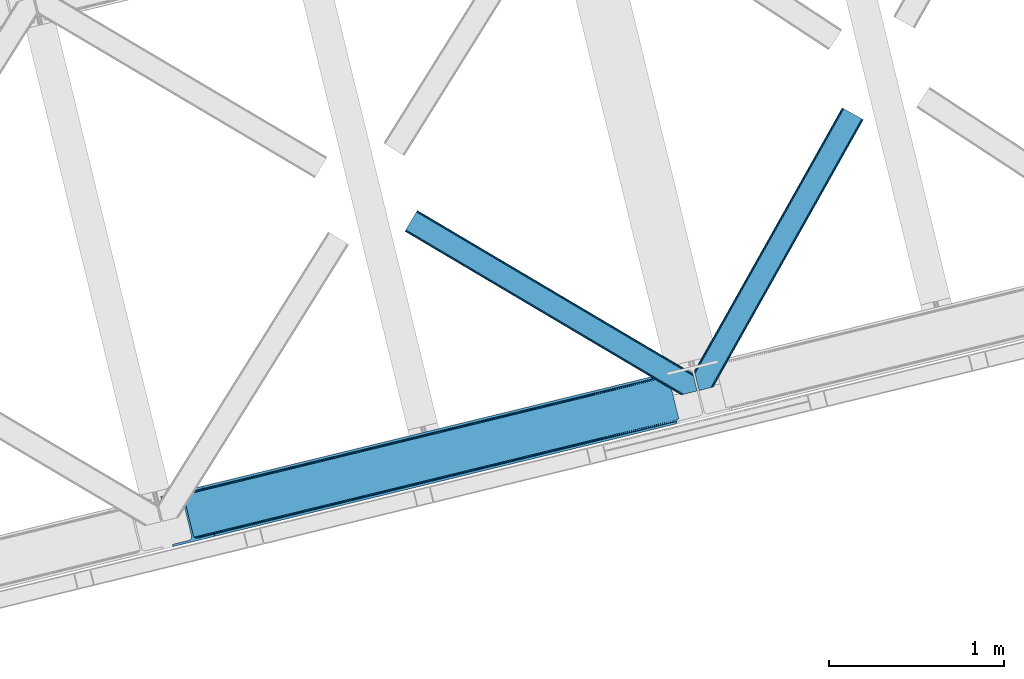
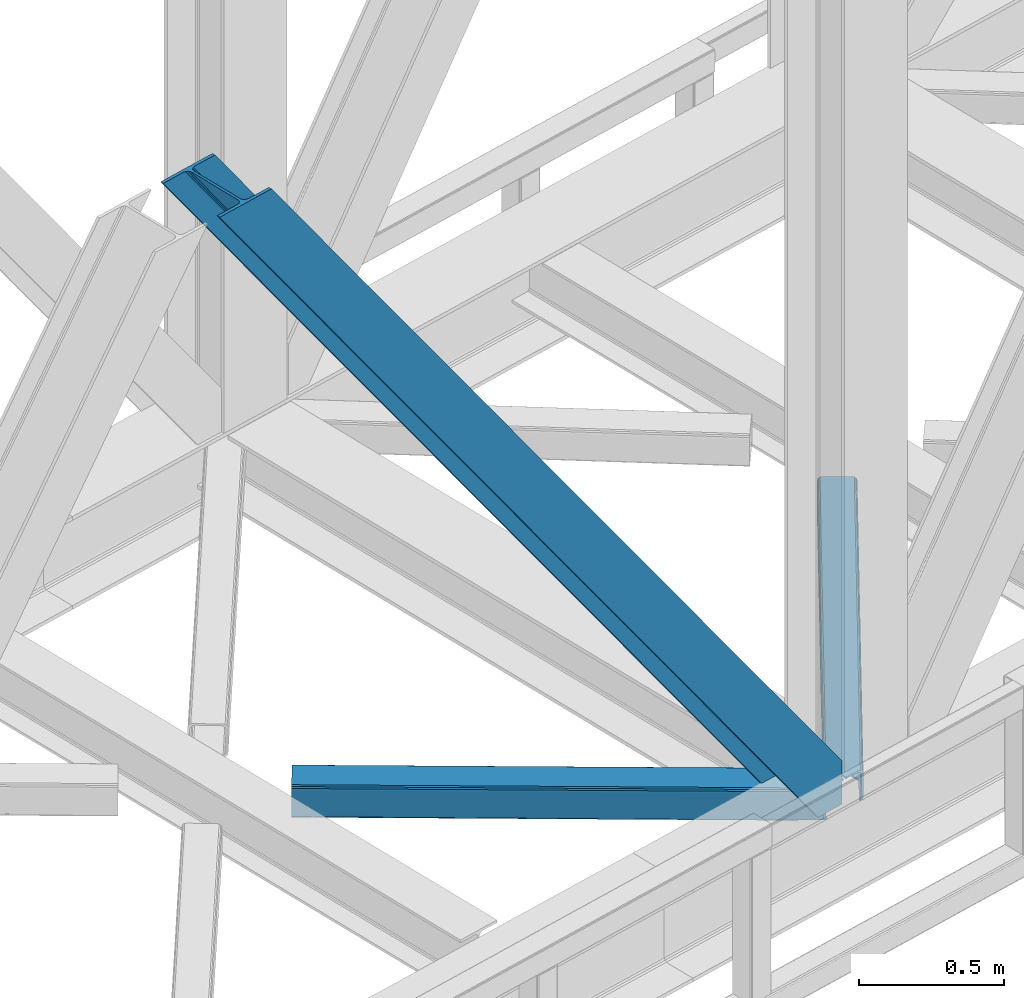
# One storey, part 69 of 93: 3 members.
"""IFC4 building model written with IfcOpenShell, lengths in millimetres."""

import ifcopenshell
import ifcopenshell.guid

model = None  # the IFC model being written
_history = None  # IfcOwnerHistory: only IFC2X3 demands one
_inside = {}  # id of a spatial element -> (the spatial element, [elements in it])
_under = {}  # id of a project, library or spatial element -> (it, [spatial elements below it])
_declared = {}  # id of a project -> (the project, [libraries it declares])
_typed = {}  # id of a type object -> (the type object, [elements of that type])
_made_of = {}  # id of a material, layer set ... -> (it, [elements and type objects made of it])


def new_model(schema):
    """Start an empty IFC model of exactly this schema.

    Asked for "IFC4X3", IfcOpenShell would pick the latest addendum, in which some entities
    have other attributes; the version numbers below select the first issue.
    IFC2X3 requires an IfcOwnerHistory on every rooted entity: one is made here for all.
    """
    global model, _history
    if schema == "IFC4X3":
        model = ifcopenshell.file(schema_version=(4, 3, 0, 0))
    else:
        model = ifcopenshell.file(schema=schema)
    _inside.clear()
    _under.clear()
    _declared.clear()
    _typed.clear()
    _made_of.clear()
    _history = None
    if model.schema == "IFC2X3":
        org = make("IfcOrganization", Name="unknown")
        user = make(
            "IfcPersonAndOrganization",
            ThePerson=make("IfcPerson", FamilyName="unknown"),
            TheOrganization=org,
        )
        app = make(
            "IfcApplication",
            ApplicationDeveloper=org,
            Version="unknown",
            ApplicationFullName="unknown",
            ApplicationIdentifier="unknown",
        )
        _history = make(
            "IfcOwnerHistory",
            OwningUser=user,
            OwningApplication=app,
            ChangeAction="ADDED",
            CreationDate=0,
        )
    return model


def make(cls, **values):
    """One entity of the class cls with the attributes given. An attribute that is None is left unset."""
    return model.create_entity(
        cls, **{name: value for name, value in values.items() if value is not None}
    )


def entity(cls, *values):
    """Any entity or typed value of the class cls, its attributes in the order of the schema. None: left unset."""
    e = model.create_entity(cls)
    for i, value in enumerate(values):
        if value is not None:
            e[i] = value
    return e


def rooted(cls, **values):
    """An entity with a GlobalId (a new one), such as an element, a storey or a relation."""
    return make(cls, GlobalId=ifcopenshell.guid.new(), OwnerHistory=_history, **values)


def si_unit(unit_type, name, prefix=None):
    """IfcSIUnit, for example si_unit("LENGTHUNIT", "METRE", prefix="MILLI")."""
    return make("IfcSIUnit", UnitType=unit_type, Prefix=prefix, Name=name)


def converted_unit(unit_type, name, factor, base, dimensions=None, offset=None):
    """IfcConversionBasedUnit, such as the inch: factor (a typed value) times the base unit."""
    return make(
        "IfcConversionBasedUnit"
        if offset is None
        else "IfcConversionBasedUnitWithOffset",
        ConversionOffset=offset,
        Dimensions=None
        if dimensions is None
        else entity("IfcDimensionalExponents", *dimensions),
        UnitType=unit_type,
        Name=name,
        ConversionFactor=make(
            "IfcMeasureWithUnit", ValueComponent=factor, UnitComponent=base
        ),
    )


def derived_unit(unit_type, elements):
    """IfcDerivedUnit: a product of units, each with its exponent."""
    return make(
        "IfcDerivedUnit",
        Elements=[
            make("IfcDerivedUnitElement", Unit=unit, Exponent=power)
            for unit, power in elements
        ],
        UnitType=unit_type,
    )


def assignment(units):
    """IfcUnitAssignment: the units of a project."""
    return None if units is None else make("IfcUnitAssignment", Units=units)


def point(xyz):
    """IfcCartesianPoint."""
    return None if xyz is None else make("IfcCartesianPoint", Coordinates=xyz)


def direction(xyz):
    """IfcDirection."""
    return None if xyz is None else make("IfcDirection", DirectionRatios=xyz)


def frame(location, z_axis=None, x_axis=None):
    """IfcAxis2Placement3D, a coordinate frame: its origin and axes. An axis left out is left unset."""
    return make(
        "IfcAxis2Placement3D",
        Location=point(location),
        Axis=direction(z_axis),
        RefDirection=direction(x_axis),
    )


def origin():
    """The frame at (0, 0, 0) with its axes left unset."""
    return frame((0.0, 0.0, 0.0))


def place(relative_to, where):
    """IfcLocalPlacement: puts the frame where relative to a parent placement (None: the world)."""
    return make(
        "IfcLocalPlacement", PlacementRelTo=relative_to, RelativePlacement=where
    )


def context(
    kind, dimensions, precision=None, world=None, true_north=None, identifier=None
):
    """IfcGeometricRepresentationContext, for example the 3D "Model" context."""
    return make(
        "IfcGeometricRepresentationContext",
        ContextIdentifier=identifier,
        ContextType=kind,
        CoordinateSpaceDimension=dimensions,
        Precision=precision,
        WorldCoordinateSystem=world,
        TrueNorth=true_north,
    )


def subcontext(parent, identifier, kind, view, scale=None):
    """IfcGeometricRepresentationSubContext, for example "Body" below "Model"."""
    return make(
        "IfcGeometricRepresentationSubContext",
        ContextIdentifier=identifier,
        ContextType=kind,
        ParentContext=parent,
        TargetScale=scale,
        TargetView=view,
    )


def project(units=None, contexts=None):
    """IfcProject with its units and contexts."""
    return rooted(
        "IfcProject",
        Name="project",
        RepresentationContexts=contexts,
        UnitsInContext=assignment(units),
    )


def spatial(cls, under=None, at=None, **own):
    """A site, building, storey or space (cls), placed at a placement, below another one or the project."""
    s = rooted(cls, ObjectPlacement=at, **own)
    if under is not None:
        _under.setdefault(under.id(), (under, []))[1].append(s)
    return s


def point_list(points):
    """IfcCartesianPointList2D or 3D."""
    cls = (
        "IfcCartesianPointList2D" if len(points[0]) == 2 else "IfcCartesianPointList3D"
    )
    return make(cls, CoordList=points)


def triangles(points, corners, closed=None, point_numbers=None):
    """IfcTriangulatedFaceSet: each triangle names its three corners, points numbered from 1."""
    return make(
        "IfcTriangulatedFaceSet",
        Coordinates=point_list(points),
        Closed=closed,
        CoordIndex=corners,
        PnIndex=point_numbers,
    )


def shape(context_of_items, identifier, shape_type, items):
    """IfcShapeRepresentation: the items that make up one representation, for example the "Body"."""
    return make(
        "IfcShapeRepresentation",
        ContextOfItems=context_of_items,
        RepresentationIdentifier=identifier,
        RepresentationType=shape_type,
        Items=items,
    )


def made_of(thing, what):
    """Note that an element or type object is made of a material, layer set ...; save() writes the relation."""
    if what is not None:
        _made_of.setdefault(what.id(), (what, []))[1].append(thing)
    return thing


def type_object(cls, material=None, **own):
    """A type object (cls), such as IfcWallType, which elements share."""
    return made_of(rooted(cls, **own), material)


def element(
    cls,
    number,
    at=None,
    inside=None,
    cuts=None,
    type_object=None,
    material=None,
    context=None,
    identifier="Body",
    shape_type=None,
    held_by="IfcProductDefinitionShape",
    body=None,
    shapes=None,
    **own,
):
    """One element of the class cls, such as IfcWall. Its Tag is "e" and its number.

    at: its placement. inside: the storey or other place that contains it. cuts: it is an
    opening in that element (IfcRelVoidsElement). A single representation is given by context,
    identifier, shape_type and body (its items); several are given by shapes. held_by: the class
    of the entity that holds the representations. save() writes the other relations.
    """
    e = rooted(cls, Tag="e%d" % number, ObjectPlacement=at, **own)
    if body is not None:
        shapes = [shape(context, identifier, shape_type, body)]
    if shapes is not None:
        e.Representation = make(held_by, Representations=shapes)
    if inside is not None:
        _inside.setdefault(inside.id(), (inside, []))[1].append(e)
    if cuts is not None:
        rooted(
            "IfcRelVoidsElement", RelatingBuildingElement=cuts, RelatedOpeningElement=e
        )
    if type_object is not None:
        _typed.setdefault(type_object.id(), (type_object, []))[1].append(e)
    return made_of(e, material)


def aggregate(whole, parts):
    """IfcRelAggregates: a whole, such as a stair, and the parts it consists of."""
    return rooted("IfcRelAggregates", RelatingObject=whole, RelatedObjects=parts)


def save(model, path):
    """Write the relations noted so far, then the file.

    IfcRelAggregates (storeys below a building ...), IfcRelContainedInSpatialStructure (elements
    in a storey), IfcRelDefinesByType, IfcRelAssociatesMaterial and IfcRelDeclares: one each for
    every whole, place, type object, material and project.
    """
    for whole, parts in _under.values():
        aggregate(whole, parts)
    for where, things in _inside.values():
        rooted(
            "IfcRelContainedInSpatialStructure",
            RelatedElements=things,
            RelatingStructure=where,
        )
    for kind, things in _typed.values():
        rooted("IfcRelDefinesByType", RelatedObjects=things, RelatingType=kind)
    for what, things in _made_of.values():
        rooted("IfcRelAssociatesMaterial", RelatedObjects=things, RelatingMaterial=what)
    for by, libraries in _declared.values():
        rooted("IfcRelDeclares", RelatingContext=by, RelatedDefinitions=libraries)
    model.write(path)


model = new_model("IFC4")

# Units and contexts
model_context = context("Model", 3, precision=0.01, world=origin(), true_north=direction((6.12303176911189e-17, 1.0)))
plan_context = context("Plan", 3, precision=0.01, world=origin(), true_north=direction((6.12303176911189e-17, 1.0)))
body_context = subcontext(model_context, "Body", "Model", "MODEL_VIEW")
ifc_project = project(units=[si_unit("LENGTHUNIT", "METRE", prefix="MILLI"), si_unit("AREAUNIT", "SQUARE_METRE"), si_unit("VOLUMEUNIT", "CUBIC_METRE"), converted_unit("PLANEANGLEUNIT", "DEGREE", entity("IfcRatioMeasure", 0.0174532925199433), si_unit("PLANEANGLEUNIT", "RADIAN"), dimensions=[0, 0, 0, 0, 0, 0, 0]), si_unit("MASSUNIT", "GRAM", prefix="KILO"), derived_unit("MASSDENSITYUNIT", [(si_unit("MASSUNIT", "GRAM", prefix="KILO"), 1), (si_unit("LENGTHUNIT", "METRE"), -3)]), derived_unit("MOMENTOFINERTIAUNIT", [(si_unit("LENGTHUNIT", "METRE"), 4)]), si_unit("TIMEUNIT", "SECOND"), si_unit("FREQUENCYUNIT", "HERTZ"), si_unit("THERMODYNAMICTEMPERATUREUNIT", "DEGREE_CELSIUS"), derived_unit("THERMALTRANSMITTANCEUNIT", [(si_unit("MASSUNIT", "GRAM", prefix="KILO"), 1), (si_unit("THERMODYNAMICTEMPERATUREUNIT", "KELVIN"), -1), (si_unit("TIMEUNIT", "SECOND"), -3)]), derived_unit("VOLUMETRICFLOWRATEUNIT", [(si_unit("LENGTHUNIT", "METRE"), 3), (si_unit("TIMEUNIT", "SECOND"), -1)]), derived_unit("MASSFLOWRATEUNIT", [(si_unit("MASSUNIT", "GRAM", prefix="KILO"), 1), (si_unit("TIMEUNIT", "SECOND"), -1)]), derived_unit("ROTATIONALFREQUENCYUNIT", [(si_unit("TIMEUNIT", "SECOND"), -1)]), si_unit("ELECTRICCURRENTUNIT", "AMPERE"), si_unit("ELECTRICVOLTAGEUNIT", "VOLT"), si_unit("POWERUNIT", "WATT"), si_unit("FORCEUNIT", "NEWTON", prefix="KILO"), si_unit("ILLUMINANCEUNIT", "LUX"), si_unit("LUMINOUSFLUXUNIT", "LUMEN"), si_unit("LUMINOUSINTENSITYUNIT", "CANDELA"), derived_unit("USERDEFINED", [(si_unit("MASSUNIT", "GRAM", prefix="KILO"), -1), (si_unit("LENGTHUNIT", "METRE"), -2), (si_unit("TIMEUNIT", "SECOND"), 3), (si_unit("LUMINOUSFLUXUNIT", "LUMEN"), 1)]), derived_unit("LINEARVELOCITYUNIT", [(si_unit("LENGTHUNIT", "METRE"), 1), (si_unit("TIMEUNIT", "SECOND"), -1)]), si_unit("PRESSUREUNIT", "PASCAL"), derived_unit("USERDEFINED", [(si_unit("LENGTHUNIT", "METRE"), -2), (si_unit("MASSUNIT", "GRAM", prefix="KILO"), 1), (si_unit("TIMEUNIT", "SECOND"), -2)]), derived_unit("LINEARFORCEUNIT", [(si_unit("MASSUNIT", "GRAM", prefix="KILO"), 1), (si_unit("LENGTHUNIT", "METRE"), 1), (si_unit("TIMEUNIT", "SECOND"), -2), (si_unit("LENGTHUNIT", "METRE"), -1)]), derived_unit("PLANARFORCEUNIT", [(si_unit("MASSUNIT", "GRAM", prefix="KILO"), 1), (si_unit("LENGTHUNIT", "METRE"), 1), (si_unit("TIMEUNIT", "SECOND"), -2), (si_unit("LENGTHUNIT", "METRE"), -2)])], contexts=[model_context, plan_context])

# Site, building, storey
site_placement = place(None, origin())
site = spatial("IfcSite", under=ifc_project, at=site_placement, CompositionType="ELEMENT")
building_placement = place(site_placement, origin())
building = spatial("IfcBuilding", under=site, at=building_placement, CompositionType="ELEMENT")
storey_placement = place(building_placement, frame((0.0, 0.0, 15900.0)))
storey = spatial("IfcBuildingStorey", under=building, at=storey_placement, CompositionType="ELEMENT", Elevation=15900.0)

# Members
member_type_1 = type_object("IfcMemberType", PredefinedType="BRACE")
member_1_placement = place(storey_placement, frame((-14085.9518371582, 14033.1887786865, 3694.99929199219)))
element("IfcMember", 1, at=member_1_placement, inside=storey, type_object=member_type_1, ObjectType="Steel Vertical Brace", PredefinedType="BRACE", context=body_context, shape_type="Tessellation", body=[
    triangles([(2966.89216003418, 730.998403930664, 0.80925292968459), (2967.55374755859, 730.015905761718, 1.10690917968532), (2966.08058166504, 729.656625366211, 0.0), (2964.18651123047, 737.429406738282, 0.0), (2962.43894348145, 728.768307495116, 8.31577148437282), (2962.43894348145, 728.768307495116, 0.0), (2505.8586730957, 612.605630493164, 658.855133056641), (2511.3606628418, 609.931375122071, 662.301434326171), (2954.04410705566, 717.839904785156, 38.6743835449197), (2954.16968078613, 719.764205932617, 32.1678039550752), (2501.41243286133, 617.533236694335, 656.552947998047), (2958.54266967773, 726.956790161132, 14.8293273925774), (2955.07776489258, 722.243124389648, 26.1867736816384), (2955.64168395996, 723.795355224609, 22.4381652832017), (655.166986083985, 156.054428100586, 3289.34108276367), (649.438265991212, 156.067218017577, 3285.27854003906), (213.882293701172, 48.4865753173817, 3911.00081176758), (205.271191406249, 47.7970825195298, 3911.00081176758), (643.936276245116, 158.742636108398, 3281.83223876953), (197.320513916016, 49.8760253906239, 3911.00081176758), (639.490036010742, 163.669079589843, 3279.53005371094), (191.242977905273, 54.4048187255848, 3911.00081176758), (636.783224487304, 170.100082397461, 3278.7231262207), (187.962945556641, 60.695132446288, 3911.00081176758), (2954.16154174805, 716.45859375, 50.6410949707024), (2517.08822021484, 609.91742248535, 666.36397705078), (2051.60849304199, 496.451092529296, 1322.10767211914), (2045.87977294922, 496.465045166015, 1318.04512939453), (1580.39888305664, 382.999877929688, 1973.78882446289), (1586.12760314941, 382.985925292967, 1977.85369262695), (1114.91799316406, 269.533547973631, 2629.53251953125), (1120.64671325684, 269.519595336913, 2633.59738769531), (2040.37778320312, 499.140463256836, 1314.598828125), (1574.89805603027, 385.674133300781, 1970.34484863281), (1109.41716613769, 272.208966064452, 2626.08854370117), (2035.93154296875, 504.066906738281, 1312.29896850586), (1570.45065307617, 390.601739501952, 1968.04266357422), (1104.97092590332, 277.135409545897, 2623.78635864258), (2498.70562133789, 623.963076782225, 655.74602050781), (2033.22473144531, 510.496746826171, 1311.48971557617), (1567.74384155273, 397.031579589842, 1967.23341064453), (1102.26411437988, 283.565249633788, 2622.97710571289), (2909.00499572754, 963.80047302246, 0.0), (2443.52526855469, 850.335305786133, 655.74602050781), (1978.04437866211, 736.868975830077, 1311.48971557617), (1512.56348876953, 623.402645874023, 1967.23341064453), (1047.08259887695, 509.937478637694, 2622.97710571289), (581.602871704101, 396.47114868164, 3278.7231262207), (132.78143005371, 287.066198730468, 3911.00081176758), (307.434722900391, 71.2909973144524, 3911.00081176758), (2954.16154174805, 716.45859375, 182.433050537107), (2954.3522277832, 715.476095581054, 0.0), (2954.16968078613, 719.764205932617, 0.0), (2954.3522277832, 715.476095581054, 182.495837402341), (2955.64168395996, 723.795355224609, 0.0), (2958.54266967773, 726.956790161132, 0.0), (2957.19507751465, 703.817504882813, 182.495837402341), (310.513604736328, 58.6603729248036, 3911.00081176758), (2957.19507751465, 703.817504882813, 0.0), (2846.09255676269, 676.734274291992, 0.0), (69.8643402099606, 0.0, 3911.00081176758), (2843.01367492676, 689.364898681641, 0.0), (66.7854583740227, 12.6294616699215, 3911.00081176758), (160.337887573241, 35.4338836669922, 3911.00081176758), (2936.56610412598, 712.169320678711, 0.0), (2953.96039123535, 734.936535644531, 0.0), (2953.94295043945, 727.841619873047, 0.0), (177.732174682616, 58.2010986328114, 3911.00081176758), (177.714733886718, 51.1073455810547, 3911.00081176758), (2950.63036193848, 721.02459411621, 0.0), (174.402145385742, 44.2891571044911, 3911.00081176758), (2944.52840881348, 715.520278930664, 0.0), (168.300192260742, 38.7848419189449, 3911.00081176758), (2898.78003845215, 961.307601928711, 0.0), (122.551821899415, 284.573327636717, 3911.00081176758), (2872.85952758789, 973.516159057617, 0.0), (2881.47062988281, 974.205651855469, 0.0), (105.243576049805, 297.47021484375, 3911.00081176758), (96.6313110351566, 296.781884765624, 3911.00081176758), (2889.42130737305, 972.1278717041, 0.0), (113.193090820312, 295.392434692381, 3911.00081176758), (2895.49884338379, 967.597915649414, 0.0), (119.271789550781, 290.86364135742, 3911.00081176758), (3.07888183593786, 273.977462768555, 3911.00081176758), (2779.30709838867, 950.711737060547, 0.0), (2776.22821655273, 963.342361450195, 0.0), (0.0, 286.606924438476, 3911.00081176758), (142.214575195312, 306.482455444335, 3911.00081176758), (150.176879882813, 309.833413696288, 3911.00081176758), (136.111459350586, 300.979302978514, 3911.00081176758), (132.800033569336, 294.161114501952, 3911.00081176758), (240.650427246093, 345.268460083007, 3911.00081176758), (243.729309082031, 332.637835693358, 3911.00081176758), (2887.33073730469, 990.424429321289, 182.495837402341), (2887.33073730469, 990.424429321289, 0.0), (2890.45496520996, 977.805432128906, 182.433050537107), (2890.17242431641, 978.765838623047, 182.495837402341), (1522.42102661133, 644.332763671875, 1977.85369262695), (591.460409545898, 417.401266479492, 3289.34108276367), (1056.94129943848, 530.867596435546, 2633.59738769531), (1987.90191650391, 757.799093627929, 1322.10767211914), (2453.38280639648, 871.264260864258, 666.36397705078), (2890.45496520996, 977.805432128906, 50.6410949707024), (2890.17242431641, 978.765838623047, 0.0), (2890.98749084473, 976.525277709961, 38.6743835449197), (2892.14904785156, 974.998626708984, 33.1630920410134), (2891.98277893066, 974.874215698243, 0.0), (2893.56989135742, 973.138275146484, 26.4425720214822), (2895.14653930664, 971.973229980469, 22.4381652832017), (2903.46928710938, 970.684936523438, 8.31577148437282), (2903.46928710938, 970.684936523438, 0.0), (2899.17652587891, 970.50122680664, 0.0), (2899.17652587891, 970.50122680664, 14.8293273925774), (2895.14653930664, 971.973229980469, 0.0), (2907.11092529297, 971.573254394531, 0.0), (2444.64961853027, 863.71007080078, 658.855133056641), (2442.96948852539, 857.289532470702, 656.552947998047), (2908.44921569824, 970.754699707031, 0.80925292968459), (2908.58409118652, 971.932534790039, 1.10690917968532), (581.047091674805, 403.426538085936, 3279.53005371094), (582.727221679688, 409.845913696288, 3281.83223876953), (586.380487060547, 414.752590942382, 3285.27854003906), (2448.30288391113, 868.615585327148, 662.301434326171), (1977.48859863281, 743.823202514648, 1312.29896850586), (1512.00770874024, 630.358035278319, 1968.04266357422), (1046.52681884766, 516.891705322265, 2623.78635864258), (1979.16872863769, 750.243740844726, 1314.598828125), (1513.68900146484, 636.777410888672, 1970.34484863281), (1048.20811157226, 523.312243652343, 2626.08854370117), (1982.82199401856, 755.15041809082, 1318.04512939453), (1517.34110412598, 641.684088134765, 1973.78882446289), (1051.86137695313, 528.218920898436, 2629.53251953125)], [[1, 2, 3], [3, 4, 1], [2, 5, 6], [6, 3, 2], [7, 8, 9], [9, 10, 7], [11, 12, 5], [5, 1, 11], [11, 7, 13], [13, 14, 11], [14, 12, 11], [15, 16, 17], [18, 17, 16], [16, 19, 18], [20, 18, 19], [19, 21, 20], [22, 20, 21], [21, 23, 22], [24, 22, 23], [5, 2, 1], [10, 13, 7], [25, 9, 8], [8, 26, 25], [26, 8, 27], [28, 27, 8], [27, 28, 29], [29, 30, 27], [30, 29, 31], [31, 32, 30], [32, 31, 16], [16, 15, 32], [8, 7, 33], [33, 28, 8], [28, 33, 34], [34, 29, 28], [29, 34, 31], [35, 31, 34], [31, 35, 16], [19, 16, 35], [7, 11, 33], [36, 33, 11], [33, 36, 34], [37, 34, 36], [34, 37, 35], [38, 35, 37], [35, 38, 21], [21, 19, 35], [1, 4, 11], [39, 11, 4], [11, 39, 36], [40, 36, 39], [36, 40, 37], [41, 37, 40], [37, 41, 38], [42, 38, 41], [38, 42, 21], [23, 21, 42], [4, 43, 44], [45, 39, 44], [41, 40, 45], [41, 45, 46], [44, 39, 4], [45, 40, 39], [42, 41, 46], [46, 47, 42], [47, 48, 23], [49, 24, 48], [47, 23, 42], [48, 24, 23], [50, 51, 30], [30, 32, 50], [32, 15, 50], [17, 50, 15], [27, 30, 51], [51, 25, 26], [26, 27, 51], [52, 9, 25], [52, 53, 10], [10, 9, 52], [25, 51, 54], [54, 52, 25], [14, 53, 55], [53, 14, 13], [10, 53, 13], [56, 12, 55], [14, 55, 12], [6, 5, 56], [12, 56, 5], [57, 54, 58], [54, 51, 50], [50, 58, 54], [57, 59, 52], [52, 54, 57], [58, 60, 57], [58, 61, 60], [60, 59, 57], [62, 60, 63], [61, 63, 60], [63, 64, 62], [65, 62, 64], [66, 67, 68], [69, 68, 67], [67, 70, 69], [71, 69, 70], [70, 72, 71], [73, 71, 72], [72, 65, 73], [64, 73, 65], [74, 66, 75], [68, 75, 66], [76, 77, 78], [78, 79, 76], [77, 80, 81], [81, 78, 77], [80, 82, 83], [83, 81, 80], [82, 74, 75], [75, 83, 82], [79, 84, 85], [85, 76, 79], [86, 85, 87], [84, 87, 85], [75, 68, 49], [71, 73, 18], [64, 61, 17], [63, 61, 64], [73, 64, 17], [68, 69, 22], [69, 71, 20], [81, 88, 78], [87, 79, 89], [79, 78, 89], [87, 84, 79], [81, 83, 90], [83, 75, 91], [49, 68, 24], [17, 18, 73], [22, 69, 20], [18, 20, 71], [22, 24, 68], [58, 17, 61], [58, 50, 17], [89, 78, 88], [90, 83, 91], [49, 91, 75], [90, 88, 81], [89, 92, 87], [92, 89, 93], [92, 86, 87], [86, 92, 94], [95, 86, 94], [96, 97, 93], [97, 94, 92], [92, 93, 97], [98, 96, 93], [93, 99, 100], [99, 93, 89], [100, 98, 93], [96, 98, 101], [101, 102, 96], [103, 96, 102], [97, 104, 94], [95, 94, 104], [104, 105, 106], [96, 103, 97], [104, 97, 103], [103, 105, 104], [107, 108, 109], [107, 106, 108], [110, 111, 112], [112, 113, 110], [113, 112, 114], [114, 109, 113], [109, 114, 107], [106, 107, 104], [53, 70, 55], [76, 86, 95], [85, 86, 76], [77, 76, 95], [104, 80, 77], [77, 95, 104], [104, 107, 80], [60, 65, 59], [52, 72, 70], [65, 72, 59], [60, 62, 65], [70, 53, 52], [52, 59, 72], [43, 66, 74], [82, 112, 74], [80, 114, 82], [80, 107, 114], [82, 114, 112], [111, 43, 74], [112, 111, 74], [43, 111, 115], [4, 66, 43], [56, 66, 6], [55, 70, 67], [67, 66, 56], [56, 55, 67], [4, 6, 66], [3, 6, 4], [116, 113, 109], [117, 118, 113], [113, 116, 117], [109, 108, 116], [118, 119, 110], [110, 113, 118], [48, 120, 91], [91, 49, 48], [120, 121, 90], [90, 91, 120], [121, 122, 88], [88, 90, 121], [122, 99, 89], [89, 88, 122], [105, 103, 123], [102, 123, 103], [106, 116, 108], [116, 106, 105], [123, 116, 105], [43, 118, 44], [117, 44, 118], [44, 117, 124], [124, 45, 44], [45, 124, 125], [125, 46, 45], [46, 125, 126], [126, 47, 46], [47, 126, 120], [120, 48, 47], [117, 116, 127], [127, 124, 117], [124, 127, 128], [128, 125, 124], [125, 128, 129], [129, 126, 125], [126, 129, 121], [121, 120, 126], [116, 123, 127], [130, 127, 123], [127, 130, 128], [131, 128, 130], [128, 131, 132], [132, 129, 128], [129, 132, 122], [122, 121, 129], [123, 102, 101], [101, 130, 123], [130, 101, 131], [98, 131, 101], [131, 98, 132], [100, 132, 98], [132, 100, 122], [99, 122, 100], [110, 119, 111], [115, 111, 119], [119, 118, 115], [43, 115, 118]]),
])
member_type_2 = type_object("IfcMemberType", PredefinedType="BRACE")
member_2_placement = place(storey_placement, frame((-11031.4278167725, 14926.1819458008, 3510.00011901855)))
element("IfcMember", 2, at=member_2_placement, inside=storey, type_object=member_type_2, ObjectType="Steel Horizontal Brace", PredefinedType="BRACE", context=body_context, shape_type="Tessellation", body=[
    triangles([(967.681631469726, 1549.66471252442, 122.500662231447), (966.517749023436, 1550.31583557129, 129.197927856447), (108.48872680664, 19.7604217529297, 122.500662231447), (106.717904663084, 19.3290527343761, 129.197927856447), (963.210974121093, 1552.17386169434, 134.874325561526), (101.675189208983, 18.1000579833999, 134.874325561526), (958.258950805663, 1554.95276184082, 138.667117309571), (94.1337890625, 16.2617980957039, 138.667117309571), (952.418609619141, 1558.23279418945, 139.999594116212), (85.2320068359368, 14.0921630859375, 139.999594116212), (967.681631469726, 1549.66471252442, 17.5000946044929), (108.48872680664, 19.7604217529297, 17.5000946044929), (6.07521057128906, 87.5702362060547, 139.999594116212), (27.4215820312493, 0.0, 139.999594116212), (860.870709228515, 1609.64826049805, 139.999594116212), (855.030368041991, 1612.92713012695, 138.667117309571), (3.75093383788953, 97.1068634033218, 138.667117309571), (850.082995605468, 1615.70719299317, 134.874325561526), (1.7801239013661, 105.192416381837, 134.874325561526), (846.772732543945, 1617.56405639648, 129.197927856447), (0.46276245117042, 110.594412231447, 129.197927856447), (845.612338256835, 1618.21750488281, 122.500662231447), (0.0, 112.491970825196, 122.500662231447), (845.612338256835, 1618.21750488281, 17.5000946044929), (0.0, 112.491970825196, 17.5000946044929), (966.517749023436, 1550.31583557129, 10.8028289794929), (963.210974121093, 1552.17386169434, 5.12526855468968), (157.746185302734, 111.400177001953, 9.52034912109593), (158.140347290038, 112.965197753907, 8.76225585937573), (158.27173461914, 113.467492675782, 8.52041015625218), (157.353186035156, 117.235867309571, 5.12526855468968), (106.36094970703, 19.2418487548839, 10.8679412841811), (105.931906127929, 19.1372039794933, 9.52034912109593), (952.418609619141, 1558.23279418945, 0.0), (958.258950805663, 1554.95276184082, 1.33247680664135), (153.058099365233, 134.858047485352, 0.0), (155.382376098632, 125.321420288086, 1.33247680664135), (124.438916015624, 252.261346435547, 0.0), (94.4581878662102, 244.952490234376, 0.0), (860.870709228515, 1609.64826049805, 0.0), (153.051123046875, 130.664117431641, 9.52034912109593), (153.142977905272, 131.5815032959, 9.31571044922021), (153.232507324217, 132.509353637695, 9.10758361816625), (153.325524902342, 133.426739501954, 8.90294494629052), (152.944152832031, 135.321972656251, 8.42274169922166), (87.952770996093, 14.7549133300781, 9.52034912109593), (150.628015136717, 144.8272064209, 6.99957275390625), (124.438916015624, 252.261346435547, 6.99957275390625), (952.15816040039, 1558.38162231445, 8.3320495605476), (946.317819213866, 1561.66049194336, 6.99957275390625), (957.105532836913, 1555.60039672852, 12.1260040283232), (92.375756835936, 15.832754516603, 12.1260040283232), (961.576190185546, 1553.09124755859, 24.4996673583992), (960.415795898436, 1553.7435333252, 17.8035644531265), (99.1858062744141, 17.4931182861328, 24.4996673583992), (97.4138214111317, 17.0617492675792, 17.8035644531265), (103.762271118163, 247.220956420899, 6.99957275390625), (866.972662353515, 1606.21940002442, 6.99957275390625), (85.5610565185543, 242.784017944337, 1.33247680664135), (91.7385864257813, 244.289739990236, 9.52034912109593), (78.0161682128892, 240.944595336914, 5.12526855468968), (95.0593139648427, 245.098992919922, 8.82504272460938), (73.7641021728505, 239.908612060548, 9.52034912109593), (846.772732543945, 1617.56405639648, 10.8028289794929), (4.59390563964735, 117.490502929688, 10.8702667236357), (850.082995605468, 1615.70719299317, 5.12526855468968), (5.69267578124891, 118.696243286133, 9.52034912109593), (855.030368041991, 1612.92713012695, 1.33247680664135), (0.0104644775383349, 112.452438354492, 16.5199218750022), (10.3889007568359, 99.4323028564468, 9.52034912109593), (7.36001586914063, 100.839193725587, 12.1260040283232), (3.09864807128906, 99.7811187744155, 16.5199218750022), (852.878173828125, 1614.13752136231, 17.8035644531265), (851.714291381835, 1614.78864440918, 24.4996673583992), (2.43008422851563, 102.522811889648, 24.4996673583992), (2.98586425781104, 100.243881225586, 17.8686767578147), (856.183786010741, 1612.27949523926, 12.1260040283232), (861.136972045897, 1609.49943237305, 8.3320495605476), (961.576190185546, 1553.09124755859, 115.501089477541), (99.1858062744141, 17.4931182861328, 115.501089477541), (97.4138214111317, 17.0617492675792, 122.196029663086), (84.8297058105454, 13.9933319091797, 131.667544555665), (75.9325744628895, 11.8248596191406, 133.000021362306), (27.4215820312493, 0.0, 133.000021362306), (92.375756835936, 15.832754516603, 127.87475280762), (946.317819213866, 1561.66049194336, 133.000021362306), (952.15816040039, 1558.38162231445, 131.667544555665), (957.105532836913, 1555.60039672852, 127.87475280762), (960.415795898436, 1553.7435333252, 122.196029663086), (856.183786010741, 1612.27949523926, 127.87475280762), (866.972662353515, 1606.21940002442, 133.000021362306), (861.136972045897, 1609.49943237305, 131.667544555665), (851.714291381835, 1614.78864440918, 115.501089477541), (852.878173828125, 1614.13752136231, 122.196029663086), (6.18101806640516, 87.1388671875011, 131.667544555665), (8.50529479980469, 77.6010772705085, 133.000021362306), (4.21020812988172, 95.2232574462905, 127.87475280762), (2.43008422851563, 102.522811889648, 115.501089477541), (2.89284667968604, 100.626416015626, 122.196029663086)], [[1, 2, 3], [4, 3, 2], [2, 5, 4], [6, 4, 5], [5, 7, 6], [8, 6, 7], [7, 9, 8], [10, 8, 9], [11, 1, 3], [3, 12, 11], [13, 10, 9], [10, 13, 14], [9, 15, 13], [15, 16, 17], [17, 13, 15], [16, 18, 19], [19, 17, 16], [18, 20, 21], [21, 19, 18], [20, 22, 23], [23, 21, 20], [22, 24, 25], [25, 23, 22], [26, 11, 12], [27, 28, 29], [30, 31, 27], [26, 32, 28], [28, 27, 26], [32, 33, 28], [34, 35, 36], [37, 36, 35], [35, 27, 37], [31, 37, 27], [12, 32, 26], [38, 39, 40], [36, 38, 34], [40, 34, 38], [41, 42, 28], [42, 43, 29], [43, 44, 29], [44, 45, 30], [33, 46, 28], [41, 28, 46], [45, 47, 36], [38, 47, 48], [47, 38, 36], [45, 31, 30], [45, 36, 37], [37, 31, 45], [49, 50, 47], [51, 49, 45], [45, 44, 51], [51, 43, 42], [43, 51, 44], [42, 41, 51], [51, 41, 52], [46, 52, 41], [47, 45, 49], [53, 54, 55], [56, 55, 54], [54, 51, 56], [52, 56, 51], [48, 47, 50], [57, 48, 58], [50, 58, 48], [59, 60, 61], [57, 38, 48], [57, 62, 39], [57, 39, 38], [39, 60, 59], [61, 60, 63], [62, 60, 39], [24, 64, 65], [65, 25, 24], [65, 64, 63], [64, 66, 61], [61, 63, 64], [63, 67, 65], [66, 68, 59], [59, 61, 66], [68, 40, 39], [39, 59, 68], [65, 69, 25], [65, 70, 71], [65, 67, 70], [71, 69, 65], [72, 69, 71], [70, 67, 60], [63, 60, 67], [73, 74, 75], [73, 72, 71], [73, 76, 72], [77, 71, 60], [60, 78, 77], [60, 62, 78], [71, 70, 60], [78, 62, 57], [57, 58, 78], [71, 77, 73], [75, 76, 73], [79, 53, 55], [55, 80, 79], [81, 3, 4], [82, 8, 10], [14, 83, 10], [83, 14, 84], [83, 82, 10], [85, 8, 82], [85, 81, 6], [6, 8, 85], [4, 6, 81], [55, 12, 3], [52, 33, 56], [81, 80, 3], [52, 46, 33], [55, 56, 12], [80, 55, 3], [32, 12, 56], [56, 33, 32], [86, 87, 82], [82, 83, 86], [87, 88, 85], [85, 82, 87], [88, 89, 81], [81, 85, 88], [89, 79, 80], [80, 81, 89], [26, 51, 54], [53, 1, 11], [26, 54, 11], [26, 27, 51], [54, 53, 11], [51, 27, 35], [50, 34, 40], [34, 49, 35], [49, 34, 50], [49, 51, 35], [2, 88, 5], [79, 1, 53], [1, 89, 2], [89, 1, 79], [2, 89, 88], [9, 86, 15], [7, 5, 88], [88, 87, 7], [87, 86, 9], [9, 7, 87], [77, 68, 66], [40, 58, 50], [40, 78, 58], [78, 40, 68], [77, 78, 68], [74, 24, 22], [64, 73, 77], [66, 64, 77], [73, 64, 24], [74, 73, 24], [16, 90, 18], [15, 86, 91], [91, 92, 15], [92, 90, 16], [16, 15, 92], [20, 18, 90], [22, 93, 74], [94, 22, 20], [22, 94, 93], [94, 20, 90], [95, 96, 13], [96, 14, 13], [96, 84, 14], [17, 95, 13], [97, 17, 19], [97, 95, 17], [72, 76, 69], [23, 98, 99], [99, 19, 21], [19, 99, 97], [21, 23, 99], [23, 75, 98], [25, 69, 76], [25, 75, 23], [75, 25, 76], [83, 96, 86], [83, 84, 96], [91, 86, 96], [74, 93, 75], [98, 75, 93], [93, 94, 98], [99, 98, 94], [94, 90, 99], [97, 99, 90], [90, 92, 97], [95, 97, 92], [92, 91, 95], [96, 95, 91]]),
])
member_type_3 = type_object("IfcMemberType", PredefinedType="BRACE")
member_3_placement = place(storey_placement, frame((-12687.8790344238, 14901.0346435547, 3510.00011901855)))
element("IfcMember", 3, at=member_3_placement, inside=storey, type_object=member_type_3, ObjectType="Steel Horizontal Brace", PredefinedType="BRACE", context=body_context, shape_type="Tessellation", body=[
    triangles([(1468.19991760254, 208.966314697265, 0.0), (1502.96058654785, 66.3657165527329, 0.0), (8.91340942382703, 950.879168701171, 0.0), (62.4054931640621, 1041.23295593262, 0.0), (0.677865600584482, 936.96722717285, 10.8028289794929), (1582.93710021973, 0.542990112304324, 10.8679412841811), (1580.70932922363, 0.0, 17.5000946044929), (1509.31950073242, 44.5019348144524, 9.52034912109593), (2.61030578613281, 940.230981445311, 5.12526855468968), (1507.05684814453, 49.5597656249993, 5.12526855468968), (1507.93353881836, 45.9669616699211, 8.52041015625218), (1508.98463745117, 44.8554016113267, 9.27850341796875), (1508.62884521484, 45.2344482421868, 9.02037963867406), (1508.26840209961, 45.6123321533196, 8.76225585937573), (1583.38939819336, 0.653448486327761, 9.52034912109593), (1505.17789306641, 57.2709228515614, 1.33247680664135), (5.50315246581886, 945.116729736328, 1.33247680664135), (0.0, 935.820785522461, 17.5000946044929), (1580.70932922363, 0.0, 122.500662231447), (0.0, 935.820785522461, 122.500662231447), (1595.73399353027, 3.66256713867188, 138.667117309571), (1605.04156494141, 5.93103332519422, 139.999594116212), (8.91340942382703, 950.879168701171, 139.999594116212), (5.50315246581886, 945.116729736328, 138.667117309571), (1587.83912658691, 1.73826599121094, 134.874325561526), (2.61030578613281, 940.230981445311, 134.874325561526), (1582.56154174805, 0.451135253904795, 129.197927856447), (0.677865600584482, 936.96722717285, 129.197927856447), (1503.00476989746, 66.183169555663, 8.52041015625218), (1503.36521301269, 65.041378784179, 8.90294494629052), (1503.8558807373, 64.3216552734375, 9.10758361816625), (1504.35003662109, 63.5914672851559, 9.31571044922021), (1504.84186706543, 62.8729064941399, 9.52034912109593), (1602.19522705078, 5.23688964843677, 9.52034912109593), (9.06572570800745, 951.139617919922, 8.3320495605476), (1502.85361633301, 66.8075500488267, 8.42274169922166), (6.17287902831958, 946.253869628905, 12.1260040283232), (1597.57225341797, 4.11021423339844, 12.1260040283232), (1500.64328613281, 75.8721130371086, 6.99957275390625), (12.4817962646484, 956.903219604492, 6.99957275390625), (1592.2946685791, 2.82424621581958, 17.8035644531265), (4.2450897216786, 942.991278076172, 17.8035644531265), (1590.44245605469, 2.3719482421875, 24.4996673583992), (3.56257324218677, 941.843673706055, 24.4996673583992), (1470.5183807373, 199.458755493164, 6.99957275390625), (58.8371063232407, 1035.2089050293, 6.99957275390625), (1463.22812805176, 229.365069580077, 8.52041015625218), (1468.15573425293, 209.147698974608, 8.52041015625218), (1464.10365600586, 225.771102905273, 5.12526855468968), (1468.30805053711, 208.524481201172, 8.42274169922166), (1465.98377380371, 218.061108398437, 1.33247680664135), (1590.44245605469, 2.3719482421875, 115.501089477541), (3.56257324218677, 941.843673706055, 115.501089477541), (1592.2946685791, 2.82424621581958, 122.196029663086), (4.2450897216786, 942.991278076172, 122.196029663086), (1597.57225341797, 4.11021423339844, 127.87475280762), (6.17287902831958, 946.253869628905, 127.87475280762), (1605.46712036133, 6.03451538085938, 131.667544555665), (9.06572570800745, 951.139617919922, 131.667544555665), (1614.77469177246, 8.30414428710901, 133.000021362306), (12.4817962646484, 956.903219604492, 133.000021362306), (1672.21072082519, 22.304452514647, 139.999594116212), (1672.21072082519, 22.304452514647, 133.000021362306), (1653.44209899902, 99.2985900878903, 139.999594116212), (62.4054931640621, 1041.23295593262, 139.999594116212), (1655.75939941406, 89.7910308837891, 133.000021362306), (58.8371063232407, 1035.2089050293, 133.000021362306), (1648.09010009766, 121.255389404296, 129.197927856447), (1647.64942932129, 123.064581298828, 122.500662231447), (70.6421997070302, 1055.14489746094, 129.197927856447), (71.3200653076165, 1056.29133911133, 122.500662231447), (1649.34583740234, 116.103378295898, 134.874325561526), (68.7085968017564, 1051.88114318848, 134.874325561526), (1651.22479248047, 108.393383789062, 138.667117309571), (65.8157501220703, 1046.99539489746, 138.667117309571), (1647.64942932129, 123.064581298828, 17.5000946044929), (71.3200653076165, 1056.29133911133, 17.5000946044929), (70.6421997070302, 1055.14489746094, 10.8028289794929), (65.1413726806641, 1045.85709228516, 12.1260040283232), (67.0738128662106, 1049.12084655762, 17.8035644531265), (67.7516784667969, 1050.26728820801, 24.4996673583992), (68.7085968017564, 1051.88114318848, 5.12526855468968), (65.8157501220703, 1046.99539489746, 1.33247680664135), (62.2485260009762, 1040.97134399414, 8.3320495605476), (65.1413726806641, 1045.85709228516, 127.87475280762), (67.7516784667969, 1050.26728820801, 115.501089477541), (67.0738128662106, 1049.12084655762, 122.196029663086), (62.2485260009762, 1040.97134399414, 131.667544555665), (1649.96672973633, 113.558184814452, 24.4996673583992), (1649.96672973633, 113.558184814452, 115.501089477541), (1653.54209289551, 98.886987304686, 131.667544555665), (1651.66313781738, 106.596981811523, 127.87475280762), (1650.40740051269, 111.748992919922, 122.196029663086), (1650.49576721191, 111.385061645507, 17.8686767578147), (1650.60390014648, 110.943228149414, 16.5199218750022), (1647.65756835937, 123.027374267578, 16.5199218750022), (1641.3730682373, 124.97144165039, 10.8702667236357), (1463.44788208008, 229.701095581055, 9.22734375000073), (1463.33974914551, 229.533663940429, 8.87387695312646), (1464.24667053223, 229.405764770507, 9.52034912109593), (1639.86618347168, 125.435366821288, 9.52034912109593), (1646.38090209961, 109.727023315429, 12.1260040283232), (1468.72546691894, 211.034793090819, 9.52034912109593), (1644.3449798584, 107.063232421875, 9.52034912109593)], [[1, 2, 3], [3, 4, 1], [5, 6, 7], [6, 5, 8], [5, 9, 10], [10, 11, 5], [12, 5, 13], [12, 8, 5], [5, 14, 13], [5, 11, 14], [8, 15, 6], [16, 10, 9], [9, 17, 16], [2, 16, 17], [17, 3, 2], [7, 18, 5], [7, 19, 18], [20, 18, 19], [21, 22, 23], [23, 24, 21], [25, 21, 24], [24, 26, 25], [27, 25, 26], [26, 28, 27], [19, 27, 28], [28, 20, 19], [11, 29, 30], [14, 30, 31], [13, 31, 32], [12, 32, 33], [33, 8, 12], [32, 12, 13], [31, 13, 14], [30, 14, 11], [34, 15, 33], [8, 33, 15], [35, 30, 29], [32, 35, 33], [35, 32, 31], [30, 35, 31], [29, 36, 35], [37, 38, 33], [33, 35, 37], [38, 34, 33], [35, 36, 39], [39, 40, 35], [41, 38, 37], [37, 42, 41], [43, 41, 42], [42, 44, 43], [39, 45, 40], [46, 40, 45], [1, 45, 39], [47, 48, 49], [48, 50, 1], [45, 1, 50], [48, 51, 49], [48, 1, 51], [2, 1, 39], [2, 39, 36], [29, 2, 36], [11, 10, 29], [29, 16, 2], [29, 10, 16], [52, 43, 44], [44, 53, 52], [54, 52, 55], [53, 55, 52], [56, 54, 57], [55, 57, 54], [58, 56, 59], [57, 59, 56], [60, 58, 61], [59, 61, 58], [56, 58, 21], [25, 56, 21], [25, 27, 54], [56, 25, 54], [54, 27, 19], [58, 22, 21], [62, 60, 63], [62, 22, 60], [58, 60, 22], [54, 19, 52], [43, 7, 41], [19, 43, 52], [7, 6, 41], [19, 7, 43], [15, 41, 6], [38, 41, 15], [34, 38, 15], [22, 64, 23], [22, 62, 64], [65, 23, 64], [66, 60, 61], [60, 66, 63], [61, 67, 66], [68, 69, 70], [71, 70, 69], [72, 68, 73], [70, 73, 68], [74, 72, 75], [73, 75, 72], [64, 74, 65], [75, 65, 74], [69, 76, 77], [77, 71, 69], [78, 79, 80], [81, 71, 77], [78, 80, 77], [78, 82, 79], [80, 81, 77], [79, 82, 83], [46, 4, 3], [4, 84, 83], [84, 4, 46], [84, 79, 83], [70, 85, 73], [86, 71, 81], [71, 87, 70], [87, 71, 86], [70, 87, 85], [65, 67, 23], [75, 73, 85], [85, 88, 75], [88, 67, 65], [65, 75, 88], [37, 17, 9], [3, 40, 46], [3, 35, 40], [35, 3, 17], [37, 35, 17], [44, 18, 20], [5, 42, 37], [9, 5, 37], [42, 5, 18], [44, 42, 18], [24, 57, 26], [23, 67, 61], [61, 59, 23], [59, 57, 24], [24, 23, 59], [28, 26, 57], [20, 53, 44], [55, 20, 28], [20, 55, 53], [55, 28, 57], [89, 90, 86], [86, 81, 89], [91, 66, 67], [67, 88, 91], [92, 91, 88], [88, 85, 92], [93, 92, 85], [85, 87, 93], [90, 93, 87], [87, 86, 90], [92, 72, 74], [66, 91, 64], [91, 92, 74], [94, 95, 96], [63, 66, 62], [64, 62, 66], [91, 74, 64], [94, 76, 89], [69, 90, 89], [89, 76, 69], [94, 96, 76], [69, 93, 90], [93, 72, 92], [72, 93, 68], [69, 68, 93], [77, 76, 97], [76, 96, 97], [98, 99, 82], [47, 82, 99], [47, 49, 82], [78, 97, 100], [100, 82, 78], [100, 98, 82], [97, 101, 100], [51, 1, 4], [4, 83, 51], [49, 51, 83], [83, 82, 49], [97, 78, 77], [80, 79, 102], [102, 95, 80], [80, 94, 89], [46, 45, 50], [103, 102, 79], [103, 104, 102], [50, 79, 84], [50, 103, 79], [50, 84, 46], [89, 81, 80], [95, 94, 80], [96, 102, 97], [102, 96, 95], [102, 101, 97], [102, 104, 101], [101, 104, 103], [103, 100, 101]]),
])

save(model, "model.ifc")
